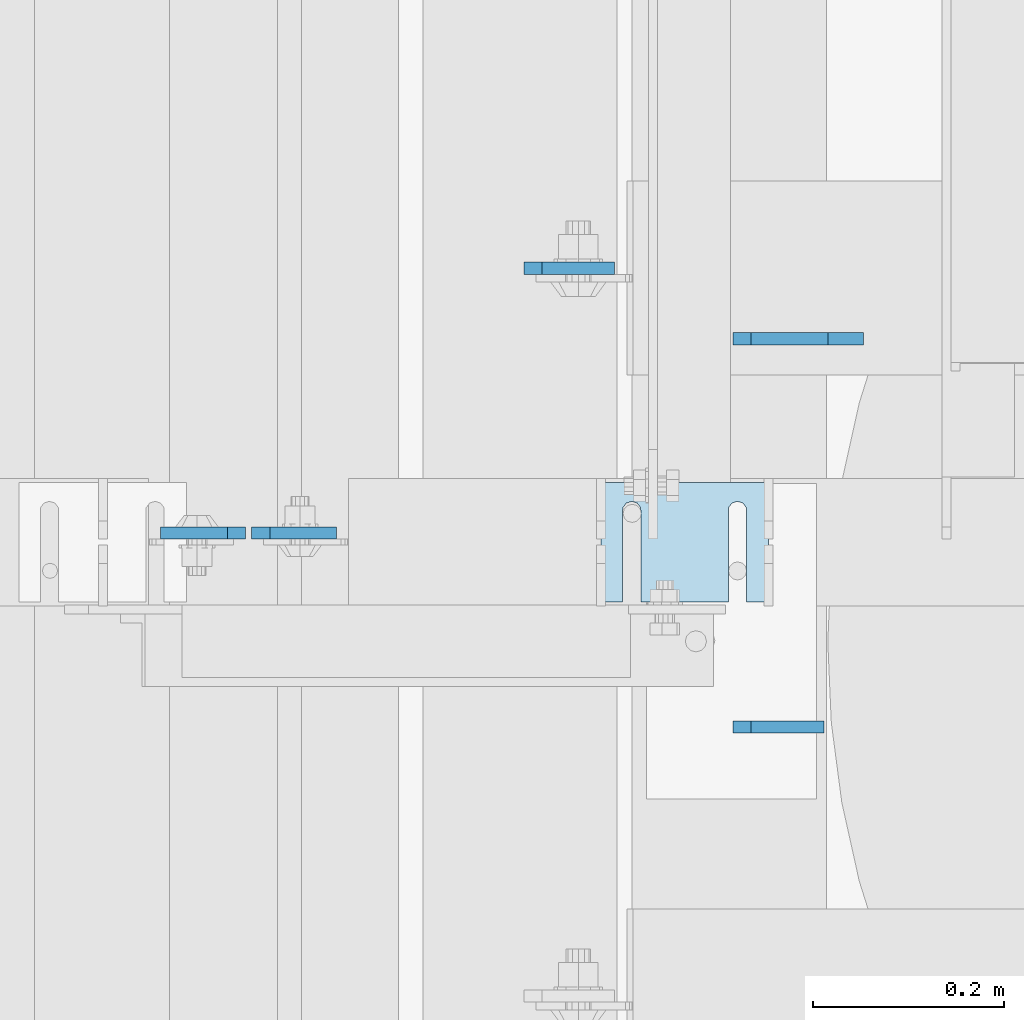
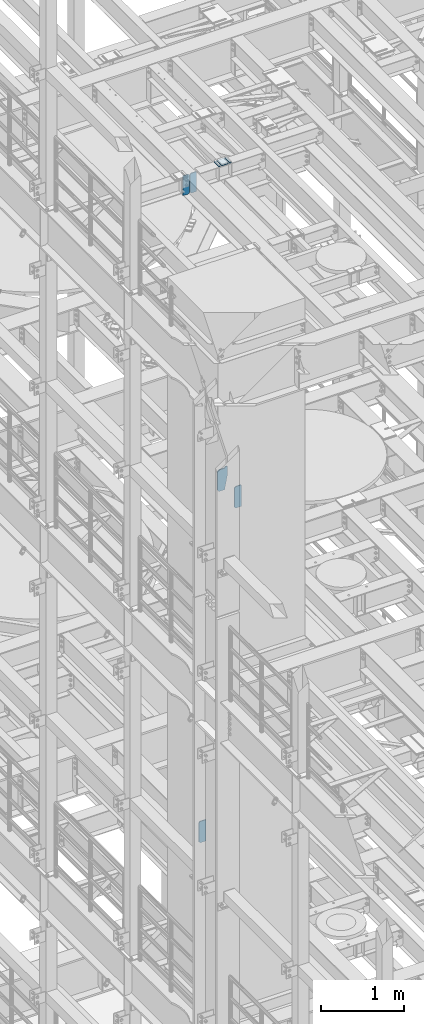
# One storey, part 1630 of 1876: 6 plates, 4 elements without a shape of their own.
"""IFC2X3 building model written with IfcOpenShell, lengths in millimetres."""

from ifc_helpers import new_model, si_unit, frame, origin_with_axes, place, context, subcontext, project, spatial, faceted_brep, material, type_object, element, aggregate, save


model = new_model("IFC2X3")

# Units and contexts
model_context = context("Model", 3, precision=1e-05, world=origin_with_axes())
body_context = subcontext(model_context, "Body", "Model", "MODEL_VIEW")
ifc_project = project(units=[si_unit("LENGTHUNIT", "METRE", prefix="MILLI"), si_unit("AREAUNIT", "SQUARE_METRE"), si_unit("VOLUMEUNIT", "CUBIC_METRE"), si_unit("MASSUNIT", "GRAM", prefix="KILO"), si_unit("TIMEUNIT", "SECOND"), si_unit("PLANEANGLEUNIT", "RADIAN"), si_unit("SOLIDANGLEUNIT", "STERADIAN"), si_unit("THERMODYNAMICTEMPERATUREUNIT", "DEGREE_CELSIUS"), si_unit("LUMINOUSINTENSITYUNIT", "LUMEN")], contexts=[model_context])

# Site, building, storey
site_placement = place(None, origin_with_axes())
site = spatial("IfcSite", under=ifc_project, at=site_placement, CompositionType="ELEMENT")
building_placement = place(site_placement, origin_with_axes())
building = spatial("IfcBuilding", under=site, at=building_placement, Name="Undefined", CompositionType="ELEMENT")
storey_placement = place(building_placement, origin_with_axes())
storey = spatial("IfcBuildingStorey", under=building, at=storey_placement, Name="Undefined", CompositionType="ELEMENT", Elevation=0.0)

# Assembly, plates
assembly_1_placement = place(storey_placement, origin_with_axes())
assembly_1 = element("IfcElementAssembly", 1, at=assembly_1_placement, inside=storey, Name="BEAM", AssemblyPlace="NOTDEFINED", PredefinedType="RIGID_FRAME")
ifc_material = material(Name="STEEL/A36")
plate_type_1 = type_object("IfcPlateType", PredefinedType="NOTDEFINED")
plate_1_placement = place(assembly_1_placement, frame((1795.4625, 5289.32356576919, 17681.575), z_axis=(0.0, 0.0, 1.0), x_axis=(-1.0, 0.0, 0.0)))
plate_1 = element("IfcPlate", 2, at=plate_1_placement, type_object=plate_type_1, material=ifc_material, Name="PLATE", context=body_context, shape_type="Brep", body=[
    faceted_brep([(0.0, -6.35000000000196, 19.0499992370605), (9.09494701772928e-13, -6.34999999999832, 273.050006866455), (-2.72848410531878e-12, 6.34999999999923, 273.050006866455), (0.0, 6.35000000000105, 19.0499992370605), (19.0499992370578, -6.35000000000696, 292.100006103516), (19.049999237056, 6.3499999999915, 292.100006103516), (88.9000015258789, -6.35000000000036, 292.100006103516), (88.9000015258789, 6.35000000000036, 292.100006103516), (88.9000015258789, -6.34999999999991, 0.0), (88.9000015258789, 6.34999999999991, 0.0), (19.0499992370642, -6.35000000000105, 0.0), (19.0499992370633, 6.35000000000105, 0.0)], [[[0, 1, 2, 3]], [[1, 4, 5, 2]], [[4, 6, 7, 5]], [[6, 8, 9, 7]], [[8, 10, 11, 9]], [[10, 0, 3, 11]], [[5, 7, 9, 11, 3, 2]], [[10, 8, 6, 4, 1, 0]]]),
])
plate_2_placement = place(assembly_1_placement, frame((1801.8125, 5289.32356576919, 17681.575), z_axis=(0.0, 0.0, 1.0), x_axis=(1.0, 0.0, 0.0)))
plate_2 = element("IfcPlate", 3, at=plate_2_placement, type_object=plate_type_1, material=ifc_material, Name="PLATE", context=body_context, shape_type="Brep", body=[
    faceted_brep([(0.0, -6.35000000000196, 19.0499992370605), (9.09494701772928e-13, -6.34999999999832, 273.050006866455), (-2.72848410531878e-12, 6.34999999999923, 273.050006866455), (0.0, 6.35000000000105, 19.0499992370605), (19.0499992370578, -6.35000000000696, 292.100006103516), (19.049999237056, 6.3499999999915, 292.100006103516), (88.9000015258789, -6.35000000000036, 292.100006103516), (88.9000015258789, 6.35000000000036, 292.100006103516), (88.9000015258789, -6.34999999999991, 0.0), (88.9000015258789, 6.34999999999991, 0.0), (19.0499992370642, -6.35000000000105, 0.0), (19.0499992370633, 6.35000000000105, 0.0)], [[[0, 1, 2, 3]], [[1, 4, 5, 2]], [[4, 6, 7, 5]], [[6, 8, 9, 7]], [[8, 10, 11, 9]], [[10, 0, 3, 11]], [[5, 7, 9, 11, 3, 2]], [[10, 8, 6, 4, 1, 0]]]),
])
aggregate(assembly_1, [plate_1, plate_2])

# Assembly, plate
assembly_2_placement = place(storey_placement, origin_with_axes())
assembly_2 = element("IfcElementAssembly", 4, at=assembly_2_placement, inside=storey, Name="BEAM", AssemblyPlace="NOTDEFINED", PredefinedType="RIGID_FRAME")
plate_type_2 = type_object("IfcPlateType", PredefinedType="NOTDEFINED")
plate_3_placement = place(assembly_2_placement, frame((2401.09375, 5086.3499993653, 12976.225), z_axis=(0.0, 0.0, 1.0), x_axis=(-1.0, 0.0, 0.0)))
plate_3 = element("IfcPlate", 5, at=plate_3_placement, type_object=plate_type_2, material=ifc_material, Name="PLATE", context=body_context, shape_type="Brep", body=[
    faceted_brep([(0.0, -6.35000000000036, 0.0), (1.81898940354586e-12, -6.35000000000127, 317.5), (0.0, 6.35000000000036, 317.5), (0.0, 6.35000000000036, 0.0), (76.2000007629395, -6.35000000000036, 317.5), (76.2000007629395, 6.35000000000036, 317.5), (95.25, -6.35000000000036, 298.450000762939), (95.25, 6.35000000000036, 298.450000762939), (95.25, -6.35000000000036, 19.0499992370605), (95.25, 6.35000000000036, 19.0499992370605), (76.2000007629395, -6.35000000000036, 0.0), (76.2000007629395, 6.35000000000036, 0.0)], [[[0, 1, 2, 3]], [[1, 4, 5, 2]], [[4, 6, 7, 5]], [[6, 8, 9, 7]], [[8, 10, 11, 9]], [[10, 0, 3, 11]], [[5, 7, 9, 11, 3, 2]], [[10, 8, 6, 4, 1, 0]]]),
])

assembly_3_placement = place(storey_placement, origin_with_axes())
assembly_3 = element("IfcElementAssembly", 6, at=assembly_3_placement, inside=storey, Name="BEAM", AssemblyPlace="NOTDEFINED", PredefinedType="RIGID_FRAME")
plate_4_placement = place(assembly_3_placement, frame((2086.76875, 5566.56875009536, 7821.6125), z_axis=(0.0, 0.0, 1.0), x_axis=(1.0, 0.0, 0.0)))
plate_4 = element("IfcPlate", 7, at=plate_4_placement, type_object=plate_type_2, material=ifc_material, Name="PLATE", context=body_context, shape_type="Brep", body=[
    faceted_brep([(0.0, -6.35000000000196, 19.0499992370605), (-9.09494701772928e-13, -6.34999999999764, 296.862506866455), (1.81898940354586e-12, 6.34999999999786, 296.862506866455), (0.0, 6.35000000000105, 19.0499992370605), (19.0499992370587, -6.34999999999604, 315.912506103516), (19.0499992370624, 6.34999999999945, 315.912506103516), (95.25, -6.35000000000036, 315.912506103516), (95.25, 6.35000000000036, 315.912506103516), (95.25, -6.35000000000036, 0.0), (95.25, 6.35000000000036, 0.0), (19.0499992370642, -6.35000000000105, 0.0), (19.0499992370633, 6.35000000000105, 0.0)], [[[0, 1, 2, 3]], [[1, 4, 5, 2]], [[4, 6, 7, 5]], [[6, 8, 9, 7]], [[8, 10, 11, 9]], [[10, 0, 3, 11]], [[5, 7, 9, 11, 3, 2]], [[10, 8, 6, 4, 1, 0]]]),
])
aggregate(assembly_3, [plate_4])

assembly_4_placement = place(storey_placement, origin_with_axes())
assembly_4 = element("IfcElementAssembly", 8, at=assembly_4_placement, inside=storey, Name="SHIM PLATE", AssemblyPlace="NOTDEFINED", PredefinedType="RIGID_FRAME")
plate_type_3 = type_object("IfcPlateType", PredefinedType="NOTDEFINED")
plate_5_placement = place(assembly_4_placement, frame((2343.14900265253, 5342.49779911347, 17987.9625), z_axis=(0.0, -1.0, 0.0), x_axis=(-1.0, 0.0, 0.0)))
plate_5 = element("IfcPlate", 9, at=plate_5_placement, type_object=plate_type_3, material=ifc_material, Name="SHIM PLATE", context=body_context, shape_type="Brep", body=[
    faceted_brep([(133.797984932592, -4.76250000000073, 125.39846801759), (133.799788185712, -4.76250000000073, 32.6385373098888), (133.799788185712, 4.76250000000073, 32.6385373098888), (133.797984932592, 4.76250000000073, 125.39846801759), (133.95251601168, -4.76250000000073, 26.6039999741197), (133.95251601168, 4.76250000000073, 26.6039999741197), (137.574395327988, -4.76250000000073, 21.7748223149583), (137.574395327988, 4.76250000000073, 21.7748223149583), (143.324785467194, -4.76250000000073, 19.9385271609622), (143.324785467194, 4.76250000000073, 19.9385271609622), (149.075176282759, -4.76250000000073, 21.7748201969102), (149.075176282759, 4.76250000000073, 21.7748201969102), (152.697057377795, -4.76250000000073, 26.6039965220207), (152.697057377795, 4.76250000000073, 26.6039965220207), (152.84978742646, -4.76250000000073, 32.6385338015343), (152.84978742646, 4.76250000000073, 32.6385338015343), (152.847984173361, -4.76250000000073, 125.398468017593), (152.847984173361, 4.76250000000073, 125.398468017593), (42.2236708188493, -4.76250000000073, 125.398468017582), (42.2236708188493, 4.76250000000073, 125.398468017582), (42.2254740719682, 4.76250000000073, 32.6385328059155), (42.2254740719682, -4.76250000000073, 32.6385328059155), (42.0727440233031, 4.76250000000073, 26.6039955264014), (42.0727440233031, -4.76250000000073, 26.6039955264014), (38.4508629282668, 4.76250000000073, 21.7748192012914), (38.4508629282668, -4.76250000000073, 21.7748192012914), (32.7004721127014, 4.76250000000073, 19.9385261653433), (32.7004721127014, -4.76250000000073, 19.9385261653433), (26.9500819734958, 4.76250000000073, 21.7748213193395), (26.9500819734958, -4.76250000000073, 21.7748213193395), (23.3282026571874, 4.76250000000073, 26.6039989785008), (23.3282026571874, -4.76250000000073, 26.6039989785008), (23.1754748312196, 4.76250000000073, 32.6385363142699), (23.1754748312196, -4.76250000000073, 32.6385363142699), (23.1736715780803, -4.76250000000073, 125.39846801758), (23.1736715780803, 4.76250000000073, 125.39846801758), (1.96497371689475e-05, 4.76250000000073, 125.398468017578), (1.96497371689475e-05, -4.76250000000073, 125.398468017578), (0.0, -4.76249999999982, 0.0), (0.0, 4.76249999999982, 0.0), (175.397720336914, -4.76250000000073, 7.27595761418343e-12), (175.397720336914, 4.76250000000073, 7.27595761418343e-12), (175.397735595691, -4.76250000000073, 125.398468017594), (175.397735595691, 4.76250000000073, 125.398468017594)], [[[0, 1, 2, 3]], [[4, 5, 2, 1]], [[6, 7, 5, 4]], [[8, 9, 7, 6]], [[10, 11, 9, 8]], [[12, 13, 11, 10]], [[14, 15, 13, 12]], [[16, 17, 15, 14]], [[18, 19, 20, 21]], [[21, 20, 22, 23]], [[23, 22, 24, 25]], [[25, 24, 26, 27]], [[27, 26, 28, 29]], [[29, 28, 30, 31]], [[31, 30, 32, 33]], [[34, 33, 32, 35]], [[36, 37, 34, 35]], [[38, 37, 36, 39]], [[40, 38, 39, 41]], [[42, 40, 41, 43]], [[12, 10, 8, 6, 4, 1, 0, 18, 21, 23, 25, 27, 29, 31, 33, 34, 37, 38, 40, 42, 16, 14]], [[19, 18, 0, 3]], [[43, 41, 39, 36, 35, 32, 30, 28, 26, 24, 22, 20, 19, 3, 2, 5, 7, 9, 11, 13, 15, 17]], [[42, 43, 17, 16]]]),
])
aggregate(assembly_4, [plate_5])

# Plate
plate_type_4 = type_object("IfcPlateType", PredefinedType="NOTDEFINED")
plate_6_placement = place(assembly_2_placement, frame((2403.47499866946, 5492.7499993653, 12976.2250305176), z_axis=(0.0, 0.0, 1.0), x_axis=(-1.0, 0.0, 0.0)))
plate_6 = element("IfcPlate", 10, at=plate_6_placement, type_object=plate_type_4, material=ifc_material, Name="PLATE", context=body_context, shape_type="Brep", body=[
    faceted_brep([(0.0, -6.35000000000036, 0.0), (-38.8939666748338, -6.34999999991305, 206.374969482462), (-38.8939666748338, 6.35000000008768, 206.374969482466), (0.0, 6.35000000000036, 0.0), (-38.8940048218228, -6.34999999985848, 333.374969482467), (-38.8940048218228, 6.35000000014224, 333.374969482475), (-1.58718562130525, -6.34999999985121, 333.374969482444), (-1.58718562130525, 6.35000000014861, 333.374969482438), (-1.58756351473312, -6.35000000001992, 317.499969482458), (-1.58756351473858, 6.34999999998013, 317.499969482449), (78.5811500548944, -6.34999999985939, 317.499994140582), (78.5811500548944, 6.35000000014134, 317.499994140577), (97.6311552428851, -6.34999999986758, 298.450000762883), (97.6311552428851, 6.35000000013315, 298.450000762878), (97.6312425231954, -6.34999999999218, 19.049999237006), (97.6312425231954, 6.35000000000855, 19.0499992370005), (78.5812492370633, -6.35000000000036, -4.18367562815547e-11), (78.5812492370633, 6.35000000000036, -4.72937244921923e-11)], [[[0, 1, 2, 3]], [[1, 4, 5, 2]], [[4, 6, 7, 5]], [[6, 8, 9, 7]], [[8, 10, 11, 9]], [[10, 12, 13, 11]], [[12, 14, 15, 13]], [[14, 16, 17, 15]], [[16, 0, 3, 17]], [[5, 7, 9, 11, 13, 15, 17, 3, 2]], [[16, 14, 12, 10, 8, 6, 4, 1, 0]]]),
])

aggregate(assembly_2, [plate_3, plate_6])

save(model, "model.ifc")
